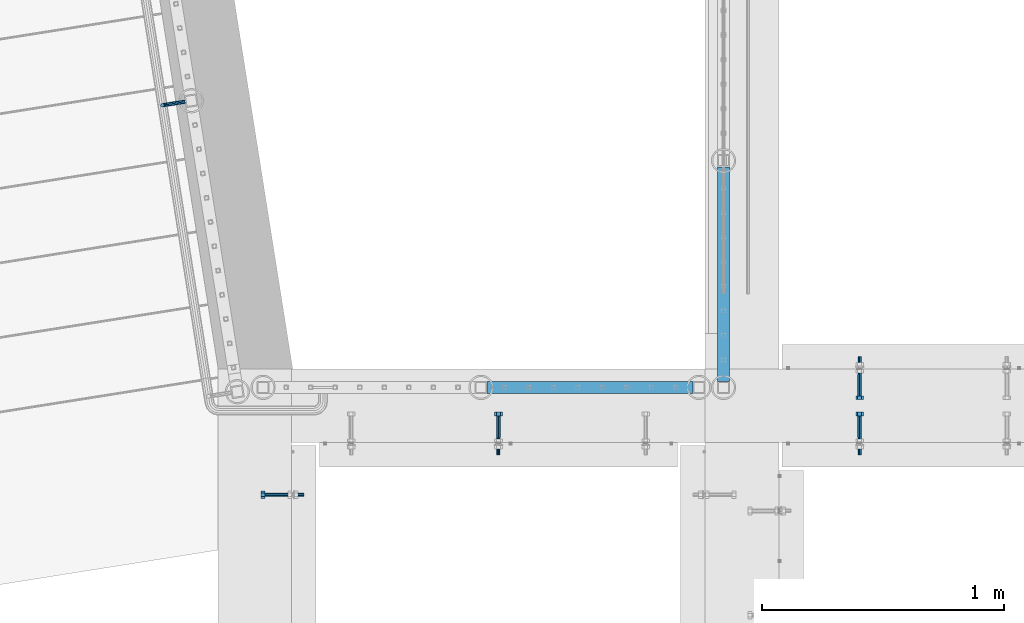
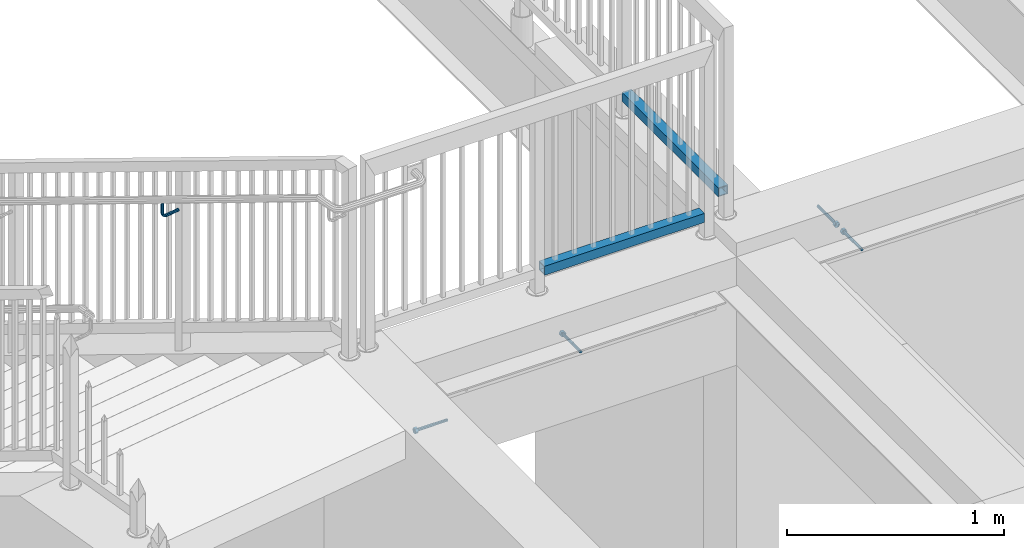
# One storey, part 426 of 975: 7 beams.
"""IFC2X3 building model written with IfcOpenShell, lengths in millimetres."""

from ifc_helpers import new_model, si_unit, frame, origin_with_axes, place, context, subcontext, project, spatial, faceted_brep, material, type_object, element, save


model = new_model("IFC2X3")

# Units and contexts
model_context = context("Model", 3, precision=1e-05, world=origin_with_axes())
body_context = subcontext(model_context, "Body", "Model", "MODEL_VIEW")
ifc_project = project(units=[si_unit("LENGTHUNIT", "METRE", prefix="MILLI"), si_unit("AREAUNIT", "SQUARE_METRE"), si_unit("VOLUMEUNIT", "CUBIC_METRE"), si_unit("MASSUNIT", "GRAM", prefix="KILO"), si_unit("TIMEUNIT", "SECOND"), si_unit("PLANEANGLEUNIT", "RADIAN"), si_unit("SOLIDANGLEUNIT", "STERADIAN"), si_unit("THERMODYNAMICTEMPERATUREUNIT", "DEGREE_CELSIUS"), si_unit("LUMINOUSINTENSITYUNIT", "LUMEN")], contexts=[model_context])

# Site, building, storey
site_placement = place(None, origin_with_axes())
site = spatial("IfcSite", under=ifc_project, at=site_placement, CompositionType="ELEMENT")
building_placement = place(site_placement, origin_with_axes())
building = spatial("IfcBuilding", under=site, at=building_placement, Name="Undefined", CompositionType="ELEMENT")
storey_placement = place(building_placement, origin_with_axes())
storey = spatial("IfcBuildingStorey", under=building, at=storey_placement, Name="Undefined", CompositionType="ELEMENT", Elevation=0.0)

# Beams
ifc_material_1 = material(Name="STEEL/A36")
beam_type_1 = type_object("IfcBeamType", PredefinedType="NOTDEFINED")
beam_1_placement = place(storey_placement, frame((-135.899616189113, 21854.8261372091, 4202.24948320932), z_axis=(0.0, 0.0, 1.0), x_axis=(-0.987688087180544, -0.156436065028609, -6.10000029016374e-08)))
element("IfcBeam", 1, at=beam_1_placement, inside=storey, type_object=beam_type_1, material=ifc_material_1, Name="BRACKET", context=body_context, shape_type="Brep", body=[
    faceted_brep([(-4.22995071858168e-07, -7.93750000000728, 0.0), (-2.99107341561466e-07, -5.61266007567065, -5.61266007566792), (69.8538229342985, -5.61266007557424, -5.61266006823735), (69.8538229337023, -7.93749999991269, 7.43239070288837e-09), (-1.09139364212751e-11, 1.81898940354586e-12, -7.9375), (69.8538229345472, 1.01863406598568e-10, -7.93749999257216), (2.99089151667431e-07, 5.61266007567428, -5.61266007566792), (69.8538229343008, 5.61266007577433, -5.61266006824189), (4.22980519942939e-07, 7.93750000001091, 0.0), (69.8538229337046, 7.93750000009823, 7.42511474527419e-09), (2.99089151667431e-07, 5.61266007567428, 5.61266007566792), (69.853822933107, 5.61266007575978, 5.61266008309485), (-1.09139364212751e-11, 1.81898940354586e-12, 7.9375), (69.8538229328592, 8.73114913702011e-11, 7.93750000742784), (-2.99107341561466e-07, -5.61266007567065, 5.61266007566792), (69.8538229331057, -5.61266007558515, 5.61266008309849), (82.6115306457523, 1.20053300634027e-10, -5.39983437816591), (81.7218529981346, -5.61266007556333, -3.25196232492181), (79.5739811551193, -7.93749999990177, 1.93345951625906), (77.4261093121045, -5.61266007558152, 7.11888135743811), (76.5364316644896, 9.09494701772928e-11, 9.26675341067767), (77.4261093121072, 5.61266007577069, 7.11888135743357), (79.5739811551225, 7.93750000011642, 1.9334595162527), (81.7218529981369, 5.61266007578888, -3.25196232492635), (91.7830833834992, 5.61266007579252, 3.47073613356315), (93.4269933452169, 1.2732925824821e-10, 1.82682594394737), (87.8143336585977, 7.93750000012005, 7.43948640866074), (83.8455839336962, 5.6126600757816, 11.408236683762), (82.2016739719761, 9.82254277914762e-11, 13.0521468733814), (83.8455839336939, -5.61266007557424, 11.4082366837665), (87.8143336585954, -7.93749999989814, 7.43948640866802), (91.7830833834973, -5.61266007555241, 3.4707361335677), (98.5057832368084, 5.61266007579252, 13.5319655869434), (100.653655166712, 1.23691279441118e-10, 12.6422876415645), (93.3203616933934, 7.93750000011642, 15.6798381488252), (88.1349401499765, 5.61266007577797, 17.8277107107078), (85.9870682200708, 9.82254277914762e-11, 18.7173886560922), (88.1349401499742, -5.61266007557424, 17.8277107107133), (93.3203616933897, -7.93749999990177, 15.6798381488315), (98.5057832368066, -5.61266007555605, 13.5319655869471), (100.86648262542, 5.61266007578524, 25.3999953235088), (103.191322549751, 1.12777343019843e-10, 25.3999950009666), (95.2538225497506, 7.93750000010914, 25.3999961022027), (89.6411624740808, 5.61266007576705, 25.3999968808967), (87.3163225497478, 9.09494701772928e-11, 25.3999972034444), (89.641162474079, -5.61266007557788, 25.3999968809012), (95.2538225497483, -7.93749999990905, 25.3999961022082), (100.866482625418, -5.61266007556333, 25.3999953235143), (103.191329597684, 6.54836185276508e-11, 76.2000105823545), (100.866489243451, -5.61266007561062, 73.1013772833176), (95.2538289897093, -7.93749999994907, 71.8178769012538), (89.6411690921104, -5.61266007562517, 73.1013665526652), (87.3163295976792, 4.36557456851006e-11, 76.1999954069215), (89.6411699519131, 5.61266007571612, 79.2986287059584), (95.2538302056541, 7.93750000005821, 80.5821290880222), (100.866490103253, 5.61266007573067, 79.2986394366098)], [[[0, 1, 2, 3]], [[1, 4, 5, 2]], [[4, 6, 7, 5]], [[6, 8, 9, 7]], [[8, 10, 11, 9]], [[10, 12, 13, 11]], [[12, 14, 15, 13]], [[14, 0, 3, 15]], [[14, 12, 10, 8, 6, 4, 1, 0]], [[2, 5, 16, 17]], [[3, 2, 17, 18]], [[15, 3, 18, 19]], [[13, 15, 19, 20]], [[11, 13, 20, 21]], [[9, 11, 21, 22]], [[7, 9, 22, 23]], [[5, 7, 23, 16]], [[23, 24, 25, 16]], [[22, 26, 24, 23]], [[21, 27, 26, 22]], [[20, 28, 27, 21]], [[19, 29, 28, 20]], [[18, 30, 29, 19]], [[17, 31, 30, 18]], [[16, 25, 31, 17]], [[24, 32, 33, 25]], [[26, 34, 32, 24]], [[27, 35, 34, 26]], [[28, 36, 35, 27]], [[29, 37, 36, 28]], [[30, 38, 37, 29]], [[31, 39, 38, 30]], [[25, 33, 39, 31]], [[32, 40, 41, 33]], [[34, 42, 40, 32]], [[35, 43, 42, 34]], [[36, 44, 43, 35]], [[37, 45, 44, 36]], [[38, 46, 45, 37]], [[39, 47, 46, 38]], [[33, 41, 47, 39]], [[47, 41, 48, 49]], [[46, 47, 49, 50]], [[45, 46, 50, 51]], [[44, 45, 51, 52]], [[43, 44, 52, 53]], [[42, 43, 53, 54]], [[40, 42, 54, 55]], [[41, 40, 55, 48]], [[54, 53, 52, 51, 50, 49, 48, 55]]]),
])
ifc_material_2 = material()
beam_type_2 = type_object("IfcBeamType", Name="HSS2X2X.188_TUBES", PredefinedType="NOTDEFINED")
beam_2_placement = place(storey_placement, frame((1088.20566764399, 20672.3889673828, 4152.90001069994), z_axis=(-3.99510000088412e-05, 0.999999999201959, 0.0), x_axis=(0.999999999201959, 3.99510000089255e-05, -8.99999966375665e-09)))
element("IfcBeam", 2, at=beam_2_placement, inside=storey, type_object=beam_type_2, material=ifc_material_2, Name="HANDRAIL", ObjectType="HSS2X2X.188_TUBES", context=body_context, shape_type="Brep", body=[
    faceted_brep([(25.3991757526369, 20.6374999999989, -20.6374999999935), (25.399175548012, -20.6375000000016, -20.6375000000626), (876.516509181093, -20.6374999996851, -20.6375000008775), (876.516509593861, 20.6375000003154, -20.6375000008593), (25.4008245513319, -20.6375000000007, 20.6374999999898), (876.518158158582, -20.6374999996851, 20.6374999991785), (25.4008247559568, 20.6374999999989, 20.6375000000589), (876.51815857135, 20.6375000003154, 20.6374999991967), (25.3989855066347, 25.3999999999987, -25.3999999999869), (25.4010150491827, 25.3999999999987, 25.4000000000742), (876.518348885611, 25.4000000003152, 25.3999999992011), (876.516319374855, 25.4000000003152, -25.4000000008637), (25.4010147973358, -25.4000000000015, 25.3999999999869), (876.518348377588, -25.399999999685, 25.3999999991829), (25.398985254787, -25.4000000000015, -25.4000000000779), (876.516318866832, -25.399999999685, -25.4000000008818)], [[[0, 1, 2, 3]], [[1, 4, 5, 2]], [[4, 6, 7, 5]], [[6, 0, 3, 7]], [[8, 9, 10, 11]], [[9, 12, 13, 10]], [[12, 14, 15, 13]], [[14, 8, 11, 15]], [[13, 15, 11, 10], [5, 7, 3, 2]], [[14, 12, 9, 8], [6, 4, 1, 0]]]),
])
beam_3_placement = place(storey_placement, frame((2091.72299660274, 20818.4707164364, 4229.09999148204), z_axis=(-0.999999996025693, 8.91550000014831e-05, 0.0), x_axis=(8.91550000020724e-05, 0.999999996025693, 1.99999948667495e-09)))
element("IfcBeam", 3, at=beam_3_placement, inside=storey, type_object=beam_type_2, material=ifc_material_2, Name="HANDRAIL", ObjectType="HSS2X2X.188_TUBES", context=body_context, shape_type="Brep", body=[
    faceted_brep([(-120.648160618501, 20.637499999998, -20.6375000000121), (-120.648160535988, -20.6375000000025, -20.6375000000194), (766.764037144734, -20.6374999999834, -20.6374999998766), (766.764008210994, 20.6375000000162, -20.6374999998693), (-120.651840408591, -20.6375000000025, 20.637499999973), (766.760357272131, -20.6374999999834, 20.6375000001158), (-120.651840491104, 20.637499999998, 20.6374999999803), (766.760328338394, 20.6375000000162, 20.6375000001231), (-120.647736027335, 25.3999999999978, -25.4000000000106), (-120.652265101304, 25.3999999999978, 25.3999999999801), (766.7599003992, 25.400000000016, 25.4000000001229), (766.764429473173, 25.400000000016, -25.3999999998678), (-120.65226499975, -25.4000000000024, 25.3999999999714), (766.759936009956, -25.3999999999833, 25.4000000001138), (-120.647735925781, -25.4000000000024, -25.4000000000196), (766.764465083928, -25.3999999999833, -25.3999999998764)], [[[0, 1, 2, 3]], [[1, 4, 5, 2]], [[4, 6, 7, 5]], [[6, 0, 3, 7]], [[8, 9, 10, 11]], [[9, 12, 13, 10]], [[12, 14, 15, 13]], [[14, 8, 11, 15]], [[13, 15, 11, 10], [5, 7, 3, 2]], [[14, 12, 9, 8], [6, 4, 1, 0]]]),
])
ifc_material_3 = material(Name="STEEL/F1554-36")
beam_type_3 = type_object("IfcBeamType", PredefinedType="NOTDEFINED")
beam_4_placement = place(storey_placement, frame((2654.82925361673, 20726.3999996637, 3886.2), z_axis=(0.0, 0.0, -1.0), x_axis=(0.0, -1.0, 0.0)))
element("IfcBeam", 4, at=beam_4_placement, inside=storey, type_object=beam_type_3, material=ifc_material_3, Name="HEADED_ANCHOR_BOLT", context=body_context, shape_type="Brep", body=[
    faceted_brep([(88.9000000184824, 7.94000001861696, -13.7499999799138), (88.8999999527368, 15.8800000758411, 2.00943759409711e-08), (104.774999952569, 15.8800001213949, 6.97191353538074e-08), (104.775000018315, 7.94000006417082, -13.7499999302891), (88.900000064019, -7.94000009583215, -13.7499999799147), (104.775000063852, -7.9400000502792, -13.74999993029), (88.9000000438027, -15.880000153059, 2.00925569515675e-08), (104.775000043643, -15.8800001075042, 6.9716406869702e-08), (88.8999999780608, -7.94000009583488, 13.7500000200998), (104.774999977893, -7.94000005028101, 13.7500000697237), (88.8999999325279, 7.94000001861514, 13.7500000201007), (104.774999932361, 7.940000064169, 13.7500000697246), (88.9000000119959, 3.78780480527439, -7.86545778426807), (88.8999999957159, 6.82538844544797, -5.4430656647246), (88.8999999799416, 8.51112018845743, -1.94260763148395), (88.8999999677944, 8.51112018845652, 1.94260767167179), (88.8999999616899, 6.82538844544615, 5.44306570491244), (88.8999999628249, 3.78780480527257, 7.86545782445592), (88.8999999709849, -3.86089595849626e-08, 8.72999956233434), (88.8999999845473, -3.7878048824914, 7.8654578244541), (88.9000000008309, -6.82538852266407, 5.44306570491153), (88.9000000166052, -8.51112026567444, 1.94260767166998), (88.9000000287488, -8.51112026567353, -1.94260763148577), (88.9000000348606, -6.82538852266407, -5.44306566472642), (88.9000000337182, -3.78780488248958, -7.86545778426898), (88.9000000255583, -3.86080500902608e-08, -8.72999952214832), (104.775000025395, 6.94581103743985e-09, -8.72999947252447), (104.775000011829, 3.78780485082825, -7.86545773464422), (104.774999995549, 6.82538849100092, -5.44306561510075), (104.774999979774, 8.51112023401038, -1.9426075818601), (104.774999967627, 8.51112023401038, 1.94260772129564), (104.774999961523, 6.82538849100092, 5.44306575453629), (104.774999962658, 3.78780485082643, 7.86545787407977), (104.774999970818, 6.94399204803631e-09, 8.7299996119591), (104.77499998438, -3.78780483693754, 7.86545787407886), (104.775000000664, -6.82538847711112, 5.44306575453538), (104.775000016438, -8.51112022012057, 1.94260772129473), (104.775000028581, -8.51112022012057, -1.94260758186101), (104.775000034693, -6.82538847711021, -5.44306561510166), (104.775000033551, -3.78780483693663, -7.86545773464422), (-2.99107341561466e-07, -5.61266007567065, 5.61266007566792), (-4.22995071858168e-07, -7.93750000000728, 0.0), (104.774999998088, -7.93749999999, -4.45652403868735e-11), (104.774999998088, -5.61266007565791, 5.61266007562426), (-1.09139364212751e-11, 1.81898940354586e-12, 7.9375), (104.774999998095, 1.18234311230481e-11, 7.93749999995816), (2.99089151667431e-07, 5.61266007567428, 5.61266007566792), (104.774999998102, 5.61266007568065, 5.61266007562517), (4.22980519942939e-07, 7.93750000001091, 0.0), (104.77499999811, 7.93750000001364, -4.36557456851006e-11), (2.99089151667431e-07, 5.61266007567428, -5.61266007566792), (104.774999998102, 5.61266007568156, -5.61266007571339), (-1.09139364212751e-11, 1.81898940354586e-12, -7.9375), (104.774999998099, 1.2732925824821e-11, -7.93750000004547), (-73.0249999592124, 5.05157065939329, -5.0515715445581), (-73.0249999269472, -1.85405951924622e-07, -7.14400069976364), (-73.0249999328516, -5.0515710302052, -5.05157154455992), (-73.0249999734697, -7.14400018541073, -6.9975976657588e-07), (-73.0250000250016, -5.05157103020611, 5.05157014504039), (-73.0250000572705, -1.85406861419324e-07, 7.1439993002441), (-73.0250000513661, 5.05157065939238, 5.05157014503948), (-73.025000010748, 7.14399981459792, -6.99758857081179e-07), (0.00625003290042514, 5.05157085007795, -5.05157087849238), (0.00625006516929716, 5.27870724909008e-09, -7.1440000336961), (0.00625005926485755, -5.05157083952145, -5.05157087849329), (0.00625001864682417, -7.14399999472516, -3.36940502165817e-08), (0.00624996711121639, -5.05157083952145, 5.05157081110519), (0.00624993484598235, 5.2777977543883e-09, 7.14399996631164), (0.00624994074678398, 5.05157085007704, 5.05157081110701), (0.00624998136845534, 7.14400000528167, -3.36922312271781e-08), (-2.99107341561466e-07, -5.61266007567065, -5.61266007566792), (104.774999998092, -5.612660075657, -5.6126600757143)], [[[0, 1, 2, 3]], [[4, 0, 3, 5]], [[6, 4, 5, 7]], [[8, 6, 7, 9]], [[10, 8, 9, 11]], [[0, 4, 6, 8, 10, 1], [12, 13, 14, 15, 16, 17, 18, 19, 20, 21, 22, 23, 24, 25]], [[12, 25, 26, 27]], [[13, 12, 27, 28]], [[14, 13, 28, 29]], [[15, 14, 29, 30]], [[16, 15, 30, 31]], [[17, 16, 31, 32]], [[18, 17, 32, 33]], [[19, 18, 33, 34]], [[20, 19, 34, 35]], [[21, 20, 35, 36]], [[22, 21, 36, 37]], [[23, 22, 37, 38]], [[24, 23, 38, 39]], [[25, 24, 39, 26]], [[9, 7, 5, 3, 2, 11], [38, 37, 36, 35, 34, 33, 32, 31, 30, 29, 28, 27, 26, 39]], [[1, 10, 11, 2]], [[40, 41, 42, 43]], [[44, 40, 43, 45]], [[46, 44, 45, 47]], [[48, 46, 47, 49]], [[50, 48, 49, 51]], [[52, 50, 51, 53]], [[54, 55, 56, 57, 58, 59, 60, 61]], [[55, 54, 62, 63]], [[56, 55, 63, 64]], [[57, 56, 64, 65]], [[58, 57, 65, 66]], [[59, 58, 66, 67]], [[60, 59, 67, 68]], [[61, 60, 68, 69]], [[54, 61, 69, 62]], [[40, 44, 46, 48, 50, 52, 70, 41], [68, 67, 66, 65, 64, 63, 62, 69]], [[41, 70, 71, 42]], [[53, 51, 49, 47, 45, 43, 42, 71]], [[70, 52, 53, 71]]]),
])
beam_5_placement = place(storey_placement, frame((2654.82925361673, 20466.05, 3886.2), z_axis=(0.0, 0.0, 1.0), x_axis=(0.0, 1.0, 0.0)))
element("IfcBeam", 5, at=beam_5_placement, inside=storey, type_object=beam_type_3, material=ifc_material_3, Name="HEADED_ANCHOR_BOLT", context=body_context, shape_type="Brep", body=[
    faceted_brep([(88.9000000184824, 7.94000001861696, -13.7499999799138), (88.8999999527368, 15.8800000758411, 2.00943759409711e-08), (104.774999952569, 15.8800001213949, 6.97191353538074e-08), (104.775000018315, 7.94000006417082, -13.7499999302891), (88.900000064019, -7.94000009583215, -13.7499999799147), (104.775000063852, -7.9400000502792, -13.74999993029), (88.9000000438027, -15.880000153059, 2.00925569515675e-08), (104.775000043643, -15.8800001075042, 6.9716406869702e-08), (88.8999999780608, -7.94000009583488, 13.7500000200998), (104.774999977893, -7.94000005028101, 13.7500000697237), (88.8999999325279, 7.94000001861514, 13.7500000201007), (104.774999932361, 7.940000064169, 13.7500000697246), (88.9000000119959, 3.78780480527439, -7.86545778426807), (88.8999999957159, 6.82538844544797, -5.4430656647246), (88.8999999799416, 8.51112018845743, -1.94260763148395), (88.8999999677944, 8.51112018845652, 1.94260767167179), (88.8999999616899, 6.82538844544615, 5.44306570491244), (88.8999999628249, 3.78780480527257, 7.86545782445592), (88.8999999709849, -3.86089595849626e-08, 8.72999956233434), (88.8999999845473, -3.7878048824914, 7.8654578244541), (88.9000000008309, -6.82538852266407, 5.44306570491153), (88.9000000166052, -8.51112026567444, 1.94260767166998), (88.9000000287488, -8.51112026567353, -1.94260763148577), (88.9000000348606, -6.82538852266407, -5.44306566472642), (88.9000000337182, -3.78780488248958, -7.86545778426898), (88.9000000255583, -3.86080500902608e-08, -8.72999952214832), (104.775000025395, 6.94581103743985e-09, -8.72999947252447), (104.775000011829, 3.78780485082825, -7.86545773464422), (104.774999995549, 6.82538849100092, -5.44306561510075), (104.774999979774, 8.51112023401038, -1.9426075818601), (104.774999967627, 8.51112023401038, 1.94260772129564), (104.774999961523, 6.82538849100092, 5.44306575453629), (104.774999962658, 3.78780485082643, 7.86545787407977), (104.774999970818, 6.94399204803631e-09, 8.7299996119591), (104.77499998438, -3.78780483693754, 7.86545787407886), (104.775000000664, -6.82538847711112, 5.44306575453538), (104.775000016438, -8.51112022012057, 1.94260772129473), (104.775000028581, -8.51112022012057, -1.94260758186101), (104.775000034693, -6.82538847711021, -5.44306561510166), (104.775000033551, -3.78780483693663, -7.86545773464422), (-2.99107341561466e-07, -5.61266007567065, 5.61266007566792), (-4.22995071858168e-07, -7.93750000000728, 0.0), (104.774999998088, -7.93749999999, -4.45652403868735e-11), (104.774999998088, -5.61266007565791, 5.61266007562426), (-1.09139364212751e-11, 1.81898940354586e-12, 7.9375), (104.774999998095, 1.18234311230481e-11, 7.93749999995816), (2.99089151667431e-07, 5.61266007567428, 5.61266007566792), (104.774999998102, 5.61266007568065, 5.61266007562517), (4.22980519942939e-07, 7.93750000001091, 0.0), (104.77499999811, 7.93750000001364, -4.36557456851006e-11), (2.99089151667431e-07, 5.61266007567428, -5.61266007566792), (104.774999998102, 5.61266007568156, -5.61266007571339), (-1.09139364212751e-11, 1.81898940354586e-12, -7.9375), (104.774999998099, 1.2732925824821e-11, -7.93750000004547), (-73.0249999592124, 5.05157065939329, -5.0515715445581), (-73.0249999269472, -1.85405951924622e-07, -7.14400069976364), (-73.0249999328516, -5.0515710302052, -5.05157154455992), (-73.0249999734697, -7.14400018541073, -6.9975976657588e-07), (-73.0250000250016, -5.05157103020611, 5.05157014504039), (-73.0250000572705, -1.85406861419324e-07, 7.1439993002441), (-73.0250000513661, 5.05157065939238, 5.05157014503948), (-73.025000010748, 7.14399981459792, -6.99758857081179e-07), (0.00625003290042514, 5.05157085007795, -5.05157087849238), (0.00625006516929716, 5.27870724909008e-09, -7.1440000336961), (0.00625005926485755, -5.05157083952145, -5.05157087849329), (0.00625001864682417, -7.14399999472516, -3.36940502165817e-08), (0.00624996711121639, -5.05157083952145, 5.05157081110519), (0.00624993484598235, 5.2777977543883e-09, 7.14399996631164), (0.00624994074678398, 5.05157085007704, 5.05157081110701), (0.00624998136845534, 7.14400000528167, -3.36922312271781e-08), (-2.99107341561466e-07, -5.61266007567065, -5.61266007566792), (104.774999998092, -5.612660075657, -5.6126600757143)], [[[0, 1, 2, 3]], [[4, 0, 3, 5]], [[6, 4, 5, 7]], [[8, 6, 7, 9]], [[10, 8, 9, 11]], [[0, 4, 6, 8, 10, 1], [12, 13, 14, 15, 16, 17, 18, 19, 20, 21, 22, 23, 24, 25]], [[12, 25, 26, 27]], [[13, 12, 27, 28]], [[14, 13, 28, 29]], [[15, 14, 29, 30]], [[16, 15, 30, 31]], [[17, 16, 31, 32]], [[18, 17, 32, 33]], [[19, 18, 33, 34]], [[20, 19, 34, 35]], [[21, 20, 35, 36]], [[22, 21, 36, 37]], [[23, 22, 37, 38]], [[24, 23, 38, 39]], [[25, 24, 39, 26]], [[9, 7, 5, 3, 2, 11], [38, 37, 36, 35, 34, 33, 32, 31, 30, 29, 28, 27, 26, 39]], [[1, 10, 11, 2]], [[40, 41, 42, 43]], [[44, 40, 43, 45]], [[46, 44, 45, 47]], [[48, 46, 47, 49]], [[50, 48, 49, 51]], [[52, 50, 51, 53]], [[54, 55, 56, 57, 58, 59, 60, 61]], [[55, 54, 62, 63]], [[56, 55, 63, 64]], [[57, 56, 64, 65]], [[58, 57, 65, 66]], [[59, 58, 66, 67]], [[60, 59, 67, 68]], [[61, 60, 68, 69]], [[54, 61, 69, 62]], [[40, 44, 46, 48, 50, 52, 70, 41], [68, 67, 66, 65, 64, 63, 62, 69]], [[41, 70, 71, 42]], [[53, 51, 49, 47, 45, 43, 42, 71]], [[70, 52, 53, 71]]]),
])
beam_6_placement = place(storey_placement, frame((1160.46250032314, 20466.0499999496, 3835.4), z_axis=(0.0, 0.0, -1.0), x_axis=(0.0, 1.0, 0.0)))
element("IfcBeam", 6, at=beam_6_placement, inside=storey, type_object=beam_type_3, material=ifc_material_3, Name="HEADED_ANCHOR_BOLT", context=body_context, shape_type="Brep", body=[
    faceted_brep([(88.9000000184824, 7.94000001861696, -13.7499999799138), (88.8999999527368, 15.8800000758411, 2.00943759409711e-08), (104.774999952569, 15.8800001213949, 6.97191353538074e-08), (104.775000018315, 7.94000006417082, -13.7499999302891), (88.900000064019, -7.94000009583215, -13.7499999799147), (104.775000063852, -7.9400000502792, -13.74999993029), (88.9000000438027, -15.880000153059, 2.00925569515675e-08), (104.775000043643, -15.8800001075042, 6.9716406869702e-08), (88.8999999780608, -7.94000009583488, 13.7500000200998), (104.774999977893, -7.94000005028101, 13.7500000697237), (88.8999999325279, 7.94000001861514, 13.7500000201007), (104.774999932361, 7.940000064169, 13.7500000697246), (88.9000000119959, 3.78780480527439, -7.86545778426807), (88.8999999957159, 6.82538844544797, -5.4430656647246), (88.8999999799416, 8.51112018845743, -1.94260763148395), (88.8999999677944, 8.51112018845652, 1.94260767167179), (88.8999999616899, 6.82538844544615, 5.44306570491244), (88.8999999628249, 3.78780480527257, 7.86545782445592), (88.8999999709849, -3.86089595849626e-08, 8.72999956233434), (88.8999999845473, -3.7878048824914, 7.8654578244541), (88.9000000008309, -6.82538852266407, 5.44306570491153), (88.9000000166052, -8.51112026567444, 1.94260767166998), (88.9000000287488, -8.51112026567353, -1.94260763148577), (88.9000000348606, -6.82538852266407, -5.44306566472642), (88.9000000337182, -3.78780488248958, -7.86545778426898), (88.9000000255583, -3.86080500902608e-08, -8.72999952214832), (104.775000025395, 6.94581103743985e-09, -8.72999947252447), (104.775000011829, 3.78780485082825, -7.86545773464422), (104.774999995549, 6.82538849100092, -5.44306561510075), (104.774999979774, 8.51112023401038, -1.9426075818601), (104.774999967627, 8.51112023401038, 1.94260772129564), (104.774999961523, 6.82538849100092, 5.44306575453629), (104.774999962658, 3.78780485082643, 7.86545787407977), (104.774999970818, 6.94399204803631e-09, 8.7299996119591), (104.77499998438, -3.78780483693754, 7.86545787407886), (104.775000000664, -6.82538847711112, 5.44306575453538), (104.775000016438, -8.51112022012057, 1.94260772129473), (104.775000028581, -8.51112022012057, -1.94260758186101), (104.775000034693, -6.82538847711021, -5.44306561510166), (104.775000033551, -3.78780483693663, -7.86545773464422), (-2.99107341561466e-07, -5.61266007567065, 5.61266007566792), (-4.22995071858168e-07, -7.93750000000728, 0.0), (104.774999998088, -7.93749999999, -4.45652403868735e-11), (104.774999998088, -5.61266007565791, 5.61266007562426), (-1.09139364212751e-11, 1.81898940354586e-12, 7.9375), (104.774999998095, 1.18234311230481e-11, 7.93749999995816), (2.99089151667431e-07, 5.61266007567428, 5.61266007566792), (104.774999998102, 5.61266007568065, 5.61266007562517), (4.22980519942939e-07, 7.93750000001091, 0.0), (104.77499999811, 7.93750000001364, -4.36557456851006e-11), (2.99089151667431e-07, 5.61266007567428, -5.61266007566792), (104.774999998102, 5.61266007568156, -5.61266007571339), (-1.09139364212751e-11, 1.81898940354586e-12, -7.9375), (104.774999998099, 1.2732925824821e-11, -7.93750000004547), (-73.0249999592124, 5.05157065939329, -5.0515715445581), (-73.0249999269472, -1.85405951924622e-07, -7.14400069976364), (-73.0249999328516, -5.0515710302052, -5.05157154455992), (-73.0249999734697, -7.14400018541073, -6.9975976657588e-07), (-73.0250000250016, -5.05157103020611, 5.05157014504039), (-73.0250000572705, -1.85406861419324e-07, 7.1439993002441), (-73.0250000513661, 5.05157065939238, 5.05157014503948), (-73.025000010748, 7.14399981459792, -6.99758857081179e-07), (0.00625003290042514, 5.05157085007795, -5.05157087849238), (0.00625006516929716, 5.27870724909008e-09, -7.1440000336961), (0.00625005926485755, -5.05157083952145, -5.05157087849329), (0.00625001864682417, -7.14399999472516, -3.36940502165817e-08), (0.00624996711121639, -5.05157083952145, 5.05157081110519), (0.00624993484598235, 5.2777977543883e-09, 7.14399996631164), (0.00624994074678398, 5.05157085007704, 5.05157081110701), (0.00624998136845534, 7.14400000528167, -3.36922312271781e-08), (-2.99107341561466e-07, -5.61266007567065, -5.61266007566792), (104.774999998092, -5.612660075657, -5.6126600757143)], [[[0, 1, 2, 3]], [[4, 0, 3, 5]], [[6, 4, 5, 7]], [[8, 6, 7, 9]], [[10, 8, 9, 11]], [[0, 4, 6, 8, 10, 1], [12, 13, 14, 15, 16, 17, 18, 19, 20, 21, 22, 23, 24, 25]], [[12, 25, 26, 27]], [[13, 12, 27, 28]], [[14, 13, 28, 29]], [[15, 14, 29, 30]], [[16, 15, 30, 31]], [[17, 16, 31, 32]], [[18, 17, 32, 33]], [[19, 18, 33, 34]], [[20, 19, 34, 35]], [[21, 20, 35, 36]], [[22, 21, 36, 37]], [[23, 22, 37, 38]], [[24, 23, 38, 39]], [[25, 24, 39, 26]], [[9, 7, 5, 3, 2, 11], [38, 37, 36, 35, 34, 33, 32, 31, 30, 29, 28, 27, 26, 39]], [[1, 10, 11, 2]], [[40, 41, 42, 43]], [[44, 40, 43, 45]], [[46, 44, 45, 47]], [[48, 46, 47, 49]], [[50, 48, 49, 51]], [[52, 50, 51, 53]], [[54, 55, 56, 57, 58, 59, 60, 61]], [[55, 54, 62, 63]], [[56, 55, 63, 64]], [[57, 56, 64, 65]], [[58, 57, 65, 66]], [[59, 58, 66, 67]], [[60, 59, 67, 68]], [[61, 60, 68, 69]], [[54, 61, 69, 62]], [[40, 44, 46, 48, 50, 52, 70, 41], [68, 67, 66, 65, 64, 63, 62, 69]], [[41, 70, 71, 42]], [[53, 51, 49, 47, 45, 43, 42, 71]], [[70, 52, 53, 71]]]),
])
beam_7_placement = place(storey_placement, frame((282.574991424881, 20227.9250242622, 3835.4), z_axis=(0.0, 0.0, -1.0), x_axis=(-0.999999999999998, 6.90000001668524e-08, 0.0)))
element("IfcBeam", 7, at=beam_7_placement, inside=storey, type_object=beam_type_3, material=ifc_material_3, Name="HEADED_ANCHOR_BOLT", context=body_context, shape_type="Brep", body=[
    faceted_brep([(88.9000000184824, 7.94000001861696, -13.7499999799138), (88.8999999527368, 15.8800000758411, 2.00943759409711e-08), (104.774999952569, 15.8800001213949, 6.97191353538074e-08), (104.775000018315, 7.94000006417082, -13.7499999302891), (88.900000064019, -7.94000009583215, -13.7499999799147), (104.775000063852, -7.9400000502792, -13.74999993029), (88.9000000438027, -15.880000153059, 2.00925569515675e-08), (104.775000043643, -15.8800001075042, 6.9716406869702e-08), (88.8999999780608, -7.94000009583488, 13.7500000200998), (104.774999977893, -7.94000005028101, 13.7500000697237), (88.8999999325279, 7.94000001861514, 13.7500000201007), (104.774999932361, 7.940000064169, 13.7500000697246), (88.9000000119959, 3.78780480527439, -7.86545778426807), (88.8999999957159, 6.82538844544797, -5.4430656647246), (88.8999999799416, 8.51112018845743, -1.94260763148395), (88.8999999677944, 8.51112018845652, 1.94260767167179), (88.8999999616899, 6.82538844544615, 5.44306570491244), (88.8999999628249, 3.78780480527257, 7.86545782445592), (88.8999999709849, -3.86089595849626e-08, 8.72999956233434), (88.8999999845473, -3.7878048824914, 7.8654578244541), (88.9000000008309, -6.82538852266407, 5.44306570491153), (88.9000000166052, -8.51112026567444, 1.94260767166998), (88.9000000287488, -8.51112026567353, -1.94260763148577), (88.9000000348606, -6.82538852266407, -5.44306566472642), (88.9000000337182, -3.78780488248958, -7.86545778426898), (88.9000000255583, -3.86080500902608e-08, -8.72999952214832), (104.775000025395, 6.94581103743985e-09, -8.72999947252447), (104.775000011829, 3.78780485082825, -7.86545773464422), (104.774999995549, 6.82538849100092, -5.44306561510075), (104.774999979774, 8.51112023401038, -1.9426075818601), (104.774999967627, 8.51112023401038, 1.94260772129564), (104.774999961523, 6.82538849100092, 5.44306575453629), (104.774999962658, 3.78780485082643, 7.86545787407977), (104.774999970818, 6.94399204803631e-09, 8.7299996119591), (104.77499998438, -3.78780483693754, 7.86545787407886), (104.775000000664, -6.82538847711112, 5.44306575453538), (104.775000016438, -8.51112022012057, 1.94260772129473), (104.775000028581, -8.51112022012057, -1.94260758186101), (104.775000034693, -6.82538847711021, -5.44306561510166), (104.775000033551, -3.78780483693663, -7.86545773464422), (-2.99107341561466e-07, -5.61266007567065, 5.61266007566792), (-4.22995071858168e-07, -7.93750000000728, 0.0), (104.774999998088, -7.93749999999, -4.45652403868735e-11), (104.774999998088, -5.61266007565791, 5.61266007562426), (-1.09139364212751e-11, 1.81898940354586e-12, 7.9375), (104.774999998095, 1.18234311230481e-11, 7.93749999995816), (2.99089151667431e-07, 5.61266007567428, 5.61266007566792), (104.774999998102, 5.61266007568065, 5.61266007562517), (4.22980519942939e-07, 7.93750000001091, 0.0), (104.77499999811, 7.93750000001364, -4.36557456851006e-11), (2.99089151667431e-07, 5.61266007567428, -5.61266007566792), (104.774999998102, 5.61266007568156, -5.61266007571339), (-1.09139364212751e-11, 1.81898940354586e-12, -7.9375), (104.774999998099, 1.2732925824821e-11, -7.93750000004547), (-73.0249999592124, 5.05157065939329, -5.0515715445581), (-73.0249999269472, -1.85405951924622e-07, -7.14400069976364), (-73.0249999328516, -5.0515710302052, -5.05157154455992), (-73.0249999734697, -7.14400018541073, -6.9975976657588e-07), (-73.0250000250016, -5.05157103020611, 5.05157014504039), (-73.0250000572705, -1.85406861419324e-07, 7.1439993002441), (-73.0250000513661, 5.05157065939238, 5.05157014503948), (-73.025000010748, 7.14399981459792, -6.99758857081179e-07), (0.00625003290042514, 5.05157085007795, -5.05157087849238), (0.00625006516929716, 5.27870724909008e-09, -7.1440000336961), (0.00625005926485755, -5.05157083952145, -5.05157087849329), (0.00625001864682417, -7.14399999472516, -3.36940502165817e-08), (0.00624996711121639, -5.05157083952145, 5.05157081110519), (0.00624993484598235, 5.2777977543883e-09, 7.14399996631164), (0.00624994074678398, 5.05157085007704, 5.05157081110701), (0.00624998136845534, 7.14400000528167, -3.36922312271781e-08), (-2.99107341561466e-07, -5.61266007567065, -5.61266007566792), (104.774999998092, -5.612660075657, -5.6126600757143)], [[[0, 1, 2, 3]], [[4, 0, 3, 5]], [[6, 4, 5, 7]], [[8, 6, 7, 9]], [[10, 8, 9, 11]], [[0, 4, 6, 8, 10, 1], [12, 13, 14, 15, 16, 17, 18, 19, 20, 21, 22, 23, 24, 25]], [[12, 25, 26, 27]], [[13, 12, 27, 28]], [[14, 13, 28, 29]], [[15, 14, 29, 30]], [[16, 15, 30, 31]], [[17, 16, 31, 32]], [[18, 17, 32, 33]], [[19, 18, 33, 34]], [[20, 19, 34, 35]], [[21, 20, 35, 36]], [[22, 21, 36, 37]], [[23, 22, 37, 38]], [[24, 23, 38, 39]], [[25, 24, 39, 26]], [[9, 7, 5, 3, 2, 11], [38, 37, 36, 35, 34, 33, 32, 31, 30, 29, 28, 27, 26, 39]], [[1, 10, 11, 2]], [[40, 41, 42, 43]], [[44, 40, 43, 45]], [[46, 44, 45, 47]], [[48, 46, 47, 49]], [[50, 48, 49, 51]], [[52, 50, 51, 53]], [[54, 55, 56, 57, 58, 59, 60, 61]], [[55, 54, 62, 63]], [[56, 55, 63, 64]], [[57, 56, 64, 65]], [[58, 57, 65, 66]], [[59, 58, 66, 67]], [[60, 59, 67, 68]], [[61, 60, 68, 69]], [[54, 61, 69, 62]], [[40, 44, 46, 48, 50, 52, 70, 41], [68, 67, 66, 65, 64, 63, 62, 69]], [[41, 70, 71, 42]], [[53, 51, 49, 47, 45, 43, 42, 71]], [[70, 52, 53, 71]]]),
])

save(model, "model.ifc")
